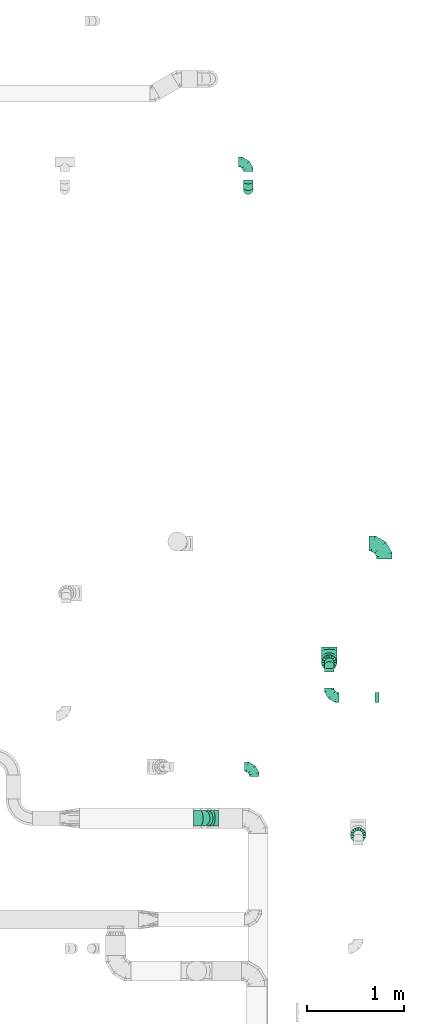
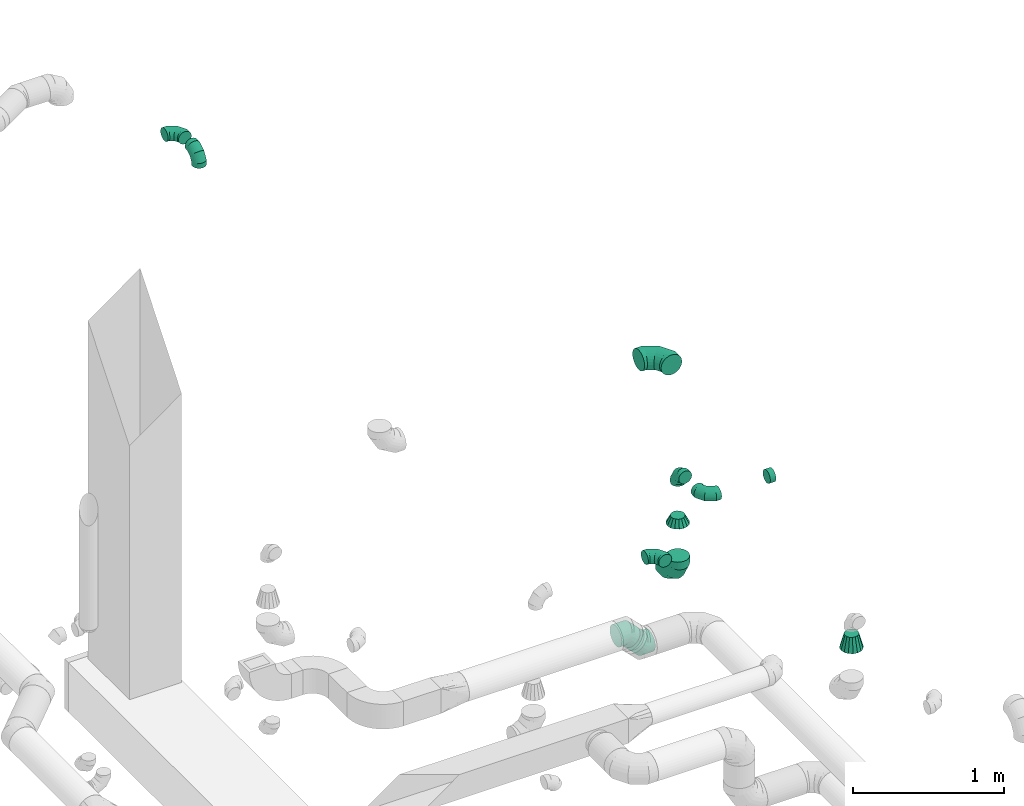
# One storey, part 83 of 97: 12 flow fittings.
"""IFC2X3 building model written with IfcOpenShell, lengths in millimetres."""

import ifcopenshell
import ifcopenshell.guid

model = None  # the IFC model being written
_history = None  # IfcOwnerHistory: only IFC2X3 demands one
_inside = {}  # id of a spatial element -> (the spatial element, [elements in it])
_under = {}  # id of a project, library or spatial element -> (it, [spatial elements below it])
_declared = {}  # id of a project -> (the project, [libraries it declares])
_typed = {}  # id of a type object -> (the type object, [elements of that type])
_made_of = {}  # id of a material, layer set ... -> (it, [elements and type objects made of it])


def new_model(schema):
    """Start an empty IFC model of exactly this schema.

    Asked for "IFC4X3", IfcOpenShell would pick the latest addendum, in which some entities
    have other attributes; the version numbers below select the first issue.
    IFC2X3 requires an IfcOwnerHistory on every rooted entity: one is made here for all.
    """
    global model, _history
    if schema == "IFC4X3":
        model = ifcopenshell.file(schema_version=(4, 3, 0, 0))
    else:
        model = ifcopenshell.file(schema=schema)
    _inside.clear()
    _under.clear()
    _declared.clear()
    _typed.clear()
    _made_of.clear()
    _history = None
    if model.schema == "IFC2X3":
        org = make("IfcOrganization", Name="unknown")
        user = make(
            "IfcPersonAndOrganization",
            ThePerson=make("IfcPerson", FamilyName="unknown"),
            TheOrganization=org,
        )
        app = make(
            "IfcApplication",
            ApplicationDeveloper=org,
            Version="unknown",
            ApplicationFullName="unknown",
            ApplicationIdentifier="unknown",
        )
        _history = make(
            "IfcOwnerHistory",
            OwningUser=user,
            OwningApplication=app,
            ChangeAction="ADDED",
            CreationDate=0,
        )
    return model


def make(cls, **values):
    """One entity of the class cls with the attributes given. An attribute that is None is left unset."""
    return model.create_entity(
        cls, **{name: value for name, value in values.items() if value is not None}
    )


def entity(cls, *values):
    """Any entity or typed value of the class cls, its attributes in the order of the schema. None: left unset."""
    e = model.create_entity(cls)
    for i, value in enumerate(values):
        if value is not None:
            e[i] = value
    return e


def rooted(cls, **values):
    """An entity with a GlobalId (a new one), such as an element, a storey or a relation."""
    return make(cls, GlobalId=ifcopenshell.guid.new(), OwnerHistory=_history, **values)


def si_unit(unit_type, name, prefix=None):
    """IfcSIUnit, for example si_unit("LENGTHUNIT", "METRE", prefix="MILLI")."""
    return make("IfcSIUnit", UnitType=unit_type, Prefix=prefix, Name=name)


def converted_unit(unit_type, name, factor, base, dimensions=None, offset=None):
    """IfcConversionBasedUnit, such as the inch: factor (a typed value) times the base unit."""
    return make(
        "IfcConversionBasedUnit"
        if offset is None
        else "IfcConversionBasedUnitWithOffset",
        ConversionOffset=offset,
        Dimensions=None
        if dimensions is None
        else entity("IfcDimensionalExponents", *dimensions),
        UnitType=unit_type,
        Name=name,
        ConversionFactor=make(
            "IfcMeasureWithUnit", ValueComponent=factor, UnitComponent=base
        ),
    )


def derived_unit(unit_type, elements):
    """IfcDerivedUnit: a product of units, each with its exponent."""
    return make(
        "IfcDerivedUnit",
        Elements=[
            make("IfcDerivedUnitElement", Unit=unit, Exponent=power)
            for unit, power in elements
        ],
        UnitType=unit_type,
    )


def assignment(units):
    """IfcUnitAssignment: the units of a project."""
    return None if units is None else make("IfcUnitAssignment", Units=units)


def point(xyz):
    """IfcCartesianPoint."""
    return None if xyz is None else make("IfcCartesianPoint", Coordinates=xyz)


def direction(xyz):
    """IfcDirection."""
    return None if xyz is None else make("IfcDirection", DirectionRatios=xyz)


def frame(location, z_axis=None, x_axis=None):
    """IfcAxis2Placement3D, a coordinate frame: its origin and axes. An axis left out is left unset."""
    return make(
        "IfcAxis2Placement3D",
        Location=point(location),
        Axis=direction(z_axis),
        RefDirection=direction(x_axis),
    )


def origin():
    """The frame at (0, 0, 0) with its axes left unset."""
    return frame((0.0, 0.0, 0.0))


def place(relative_to, where):
    """IfcLocalPlacement: puts the frame where relative to a parent placement (None: the world)."""
    return make(
        "IfcLocalPlacement", PlacementRelTo=relative_to, RelativePlacement=where
    )


def context(
    kind, dimensions, precision=None, world=None, true_north=None, identifier=None
):
    """IfcGeometricRepresentationContext, for example the 3D "Model" context."""
    return make(
        "IfcGeometricRepresentationContext",
        ContextIdentifier=identifier,
        ContextType=kind,
        CoordinateSpaceDimension=dimensions,
        Precision=precision,
        WorldCoordinateSystem=world,
        TrueNorth=true_north,
    )


def subcontext(parent, identifier, kind, view, scale=None):
    """IfcGeometricRepresentationSubContext, for example "Body" below "Model"."""
    return make(
        "IfcGeometricRepresentationSubContext",
        ContextIdentifier=identifier,
        ContextType=kind,
        ParentContext=parent,
        TargetScale=scale,
        TargetView=view,
    )


def project(units=None, contexts=None):
    """IfcProject with its units and contexts."""
    return rooted(
        "IfcProject",
        Name="project",
        RepresentationContexts=contexts,
        UnitsInContext=assignment(units),
    )


def spatial(cls, under=None, at=None, **own):
    """A site, building, storey or space (cls), placed at a placement, below another one or the project."""
    s = rooted(cls, ObjectPlacement=at, **own)
    if under is not None:
        _under.setdefault(under.id(), (under, []))[1].append(s)
    return s


def faces_of(points, faces, orient=None, outer=None):
    """IfcFace entities. A face is a list of loops; a loop is a list of indices into points, from 0.

    orient and outer hold one flag for each loop. By default every Orientation is true, the
    first loop of a face is its IfcFaceOuterBound and the others are IfcFaceBound.
    """
    made = []
    for i, loops in enumerate(faces):
        bounds = []
        for j, loop in enumerate(loops):
            is_outer = j == 0 if outer is None else outer[i][j]
            bounds.append(
                make(
                    "IfcFaceOuterBound" if is_outer else "IfcFaceBound",
                    Bound=make("IfcPolyLoop", Polygon=[points[k] for k in loop]),
                    Orientation=True if orient is None else orient[i][j],
                )
            )
        made.append(make("IfcFace", Bounds=bounds))
    return made


def faceted_brep(points, faces, orient=None, outer=None, voids=None):
    """IfcFacetedBrep: a solid bounded by flat faces; with voids (closed shells), ...WithVoids."""
    shared = [point(p) for p in points]
    hull = make("IfcClosedShell", CfsFaces=faces_of(shared, faces, orient, outer))
    if voids is None:
        return make("IfcFacetedBrep", Outer=hull)
    return make(
        "IfcFacetedBrepWithVoids",
        Outer=hull,
        Voids=[
            make(cls, CfsFaces=faces_of(shared, fs, o, b)) for cls, fs, o, b in voids
        ],
    )


def shape(context_of_items, identifier, shape_type, items):
    """IfcShapeRepresentation: the items that make up one representation, for example the "Body"."""
    return make(
        "IfcShapeRepresentation",
        ContextOfItems=context_of_items,
        RepresentationIdentifier=identifier,
        RepresentationType=shape_type,
        Items=items,
    )


def source(mapping_origin, context_of_items, identifier, shape_type, items):
    """IfcRepresentationMap: a shape defined once, which mapped items show again and again."""
    return make(
        "IfcRepresentationMap",
        MappingOrigin=mapping_origin,
        MappedRepresentation=shape(context_of_items, identifier, shape_type, items),
    )


def transform(
    local_origin,
    x_axis=None,
    y_axis=None,
    z_axis=None,
    scale=None,
    scale2=None,
    scale3=None,
    uniform=True,
):
    """IfcCartesianTransformationOperator3D, or its non-uniform kind. x_axis, y_axis, z_axis: its Axis1, 2, 3."""
    if uniform:
        return make(
            "IfcCartesianTransformationOperator3D",
            Axis1=direction(x_axis),
            Axis2=direction(y_axis),
            LocalOrigin=point(local_origin),
            Scale=scale,
            Axis3=direction(z_axis),
        )
    return make(
        "IfcCartesianTransformationOperator3DnonUniform",
        Axis1=direction(x_axis),
        Axis2=direction(y_axis),
        LocalOrigin=point(local_origin),
        Scale=scale,
        Axis3=direction(z_axis),
        Scale2=scale2,
        Scale3=scale3,
    )


def mapped(mapping_source, mapping_target):
    """IfcMappedItem: shows the shape of a source again, moved by a transform."""
    return make(
        "IfcMappedItem", MappingSource=mapping_source, MappingTarget=mapping_target
    )


def material(Name=None, Category=None):
    """IfcMaterial."""
    return make("IfcMaterial", Name=Name, Category=Category)


def made_of(thing, what):
    """Note that an element or type object is made of a material, layer set ...; save() writes the relation."""
    if what is not None:
        _made_of.setdefault(what.id(), (what, []))[1].append(thing)
    return thing


def type_object(cls, material=None, **own):
    """A type object (cls), such as IfcWallType, which elements share."""
    return made_of(rooted(cls, **own), material)


def type_shapes(of_type, sources):
    """Give a type object the sources (RepresentationMaps) that its elements show as mapped items."""
    of_type.RepresentationMaps = sources


def element(
    cls,
    number,
    at=None,
    inside=None,
    cuts=None,
    type_object=None,
    material=None,
    context=None,
    identifier="Body",
    shape_type=None,
    held_by="IfcProductDefinitionShape",
    body=None,
    shapes=None,
    **own,
):
    """One element of the class cls, such as IfcWall. Its Tag is "e" and its number.

    at: its placement. inside: the storey or other place that contains it. cuts: it is an
    opening in that element (IfcRelVoidsElement). A single representation is given by context,
    identifier, shape_type and body (its items); several are given by shapes. held_by: the class
    of the entity that holds the representations. save() writes the other relations.
    """
    e = rooted(cls, Tag="e%d" % number, ObjectPlacement=at, **own)
    if body is not None:
        shapes = [shape(context, identifier, shape_type, body)]
    if shapes is not None:
        e.Representation = make(held_by, Representations=shapes)
    if inside is not None:
        _inside.setdefault(inside.id(), (inside, []))[1].append(e)
    if cuts is not None:
        rooted(
            "IfcRelVoidsElement", RelatingBuildingElement=cuts, RelatedOpeningElement=e
        )
    if type_object is not None:
        _typed.setdefault(type_object.id(), (type_object, []))[1].append(e)
    return made_of(e, material)


def aggregate(whole, parts):
    """IfcRelAggregates: a whole, such as a stair, and the parts it consists of."""
    return rooted("IfcRelAggregates", RelatingObject=whole, RelatedObjects=parts)


def save(model, path):
    """Write the relations noted so far, then the file.

    IfcRelAggregates (storeys below a building ...), IfcRelContainedInSpatialStructure (elements
    in a storey), IfcRelDefinesByType, IfcRelAssociatesMaterial and IfcRelDeclares: one each for
    every whole, place, type object, material and project.
    """
    for whole, parts in _under.values():
        aggregate(whole, parts)
    for where, things in _inside.values():
        rooted(
            "IfcRelContainedInSpatialStructure",
            RelatedElements=things,
            RelatingStructure=where,
        )
    for kind, things in _typed.values():
        rooted("IfcRelDefinesByType", RelatedObjects=things, RelatingType=kind)
    for what, things in _made_of.values():
        rooted("IfcRelAssociatesMaterial", RelatedObjects=things, RelatingMaterial=what)
    for by, libraries in _declared.values():
        rooted("IfcRelDeclares", RelatingContext=by, RelatedDefinitions=libraries)
    model.write(path)


model = new_model("IFC2X3")

# Units and contexts
model_context = context("Model", 3, precision=0.01, world=origin(), true_north=direction((6.12303176911189e-17, 1.0)))
body_context = subcontext(model_context, "Body", "Model", "MODEL_VIEW")
ifc_project = project(units=[si_unit("LENGTHUNIT", "METRE", prefix="MILLI"), si_unit("AREAUNIT", "SQUARE_METRE"), si_unit("VOLUMEUNIT", "CUBIC_METRE"), converted_unit("PLANEANGLEUNIT", "DEGREE", entity("IfcRatioMeasure", 0.0174532925199433), si_unit("PLANEANGLEUNIT", "RADIAN"), dimensions=[0, 0, 0, 0, 0, 0, 0]), si_unit("MASSUNIT", "GRAM", prefix="KILO"), derived_unit("MASSDENSITYUNIT", [(si_unit("MASSUNIT", "GRAM", prefix="KILO"), 1), (si_unit("LENGTHUNIT", "METRE"), -3)]), derived_unit("MOMENTOFINERTIAUNIT", [(si_unit("LENGTHUNIT", "METRE"), 4)]), si_unit("TIMEUNIT", "SECOND"), si_unit("FREQUENCYUNIT", "HERTZ"), si_unit("THERMODYNAMICTEMPERATUREUNIT", "DEGREE_CELSIUS"), derived_unit("THERMALTRANSMITTANCEUNIT", [(si_unit("MASSUNIT", "GRAM", prefix="KILO"), 1), (si_unit("THERMODYNAMICTEMPERATUREUNIT", "KELVIN"), -1), (si_unit("TIMEUNIT", "SECOND"), -3)]), derived_unit("VOLUMETRICFLOWRATEUNIT", [(si_unit("LENGTHUNIT", "METRE"), 3), (si_unit("TIMEUNIT", "SECOND"), -1)]), derived_unit("MASSFLOWRATEUNIT", [(si_unit("MASSUNIT", "GRAM", prefix="KILO"), 1), (si_unit("TIMEUNIT", "SECOND"), -1)]), derived_unit("ROTATIONALFREQUENCYUNIT", [(si_unit("TIMEUNIT", "SECOND"), -1)]), si_unit("ELECTRICCURRENTUNIT", "AMPERE"), si_unit("ELECTRICVOLTAGEUNIT", "VOLT"), si_unit("POWERUNIT", "WATT"), si_unit("FORCEUNIT", "NEWTON", prefix="KILO"), si_unit("ILLUMINANCEUNIT", "LUX"), si_unit("LUMINOUSFLUXUNIT", "LUMEN"), si_unit("LUMINOUSINTENSITYUNIT", "CANDELA"), derived_unit("USERDEFINED", [(si_unit("MASSUNIT", "GRAM", prefix="KILO"), -1), (si_unit("LENGTHUNIT", "METRE"), -2), (si_unit("TIMEUNIT", "SECOND"), 3), (si_unit("LUMINOUSFLUXUNIT", "LUMEN"), 1)]), derived_unit("LINEARVELOCITYUNIT", [(si_unit("LENGTHUNIT", "METRE"), 1), (si_unit("TIMEUNIT", "SECOND"), -1)]), si_unit("PRESSUREUNIT", "PASCAL"), derived_unit("USERDEFINED", [(si_unit("LENGTHUNIT", "METRE"), -2), (si_unit("MASSUNIT", "GRAM", prefix="KILO"), 1), (si_unit("TIMEUNIT", "SECOND"), -2)]), derived_unit("LINEARFORCEUNIT", [(si_unit("MASSUNIT", "GRAM", prefix="KILO"), 1), (si_unit("LENGTHUNIT", "METRE"), 1), (si_unit("TIMEUNIT", "SECOND"), -2), (si_unit("LENGTHUNIT", "METRE"), -1)]), derived_unit("PLANARFORCEUNIT", [(si_unit("MASSUNIT", "GRAM", prefix="KILO"), 1), (si_unit("LENGTHUNIT", "METRE"), 1), (si_unit("TIMEUNIT", "SECOND"), -2), (si_unit("LENGTHUNIT", "METRE"), -2)])], contexts=[model_context])

# Site, building, storey
site_placement = place(None, origin())
site = spatial("IfcSite", under=ifc_project, at=site_placement, CompositionType="ELEMENT")
building_placement = place(site_placement, origin())
building = spatial("IfcBuilding", under=site, at=building_placement, CompositionType="ELEMENT")
storey_placement = place(building_placement, frame((0.0, 0.0, -4900.0)))
storey = spatial("IfcBuildingStorey", under=building, at=storey_placement, CompositionType="ELEMENT", Elevation=-4900.0)

# Flow fittings
ifc_material = material()
duct_fitting_type_1 = type_object("IfcDuctFittingType", PredefinedType="NOTDEFINED", material=ifc_material)
shared_shape_1 = source(origin(), body_context, "Body", "Brep", [
    faceted_brep([(-160.0, 0.0, -80.0), (-160.0, -20.71, -77.27), (-160.0, -40.0, -69.28), (-160.0, -56.57, -56.57), (-160.0, -69.28, -40.0), (-160.0, -77.27, -20.71), (-160.0, -80.0, 0.0), (-160.0, -77.27, 20.71), (-160.0, -69.28, 40.0), (-160.0, -56.57, 56.57), (-160.0, -40.0, 69.28), (-160.0, -20.71, 77.27), (-160.0, 0.0, 80.0), (-160.0, 20.71, 77.27), (-160.0, 40.0, 69.28), (-160.0, 56.57, 56.57), (-160.0, 69.28, 40.0), (-160.0, 77.27, 20.71), (-160.0, 80.0, 0.0), (-160.0, 77.27, -20.71), (-160.0, 69.28, -40.0), (-160.0, 56.57, -56.57), (-160.0, 40.0, -69.28), (-160.0, 20.71, -77.27), (-122.68, 20.71, 77.27), (-127.85, 40.0, 69.28), (-117.13, 0.0, 80.0), (-132.29, 56.57, 56.57), (-137.83, 77.27, 20.71), (-138.56, 80.0, 0.0), (-135.69, 69.28, 40.0), (-135.69, 69.28, -40.0), (-132.29, 56.57, -56.57), (-137.83, 77.27, -20.71), (-122.68, 20.71, -77.27), (-117.13, 0.0, -80.0), (-127.85, 40.0, -69.28), (-111.58, -20.71, -77.27), (-106.41, -40.0, -69.28), (-101.97, -56.57, -56.57), (-98.56, -69.28, -40.0), (-96.42, -77.27, -20.71), (-95.69, -80.0, 0.0), (-96.42, -77.27, 20.71), (-98.56, -69.28, 40.0), (-101.97, -56.57, 56.57), (-106.41, -40.0, 69.28), (-111.58, -20.71, 77.27), (-58.03, 58.03, 77.27), (-72.15, 72.15, 69.28), (-42.87, 42.87, 80.0), (-84.28, 84.28, 56.57), (-93.59, 93.59, 40.0), (-99.44, 99.44, 20.71), (-101.44, 101.44, 0.0), (-99.44, 99.44, -20.71), (-93.59, 93.59, -40.0), (-84.28, 84.28, -56.57), (-58.03, 58.03, -77.27), (-42.87, 42.87, -80.0), (-72.15, 72.15, -69.28), (-27.71, 27.71, -77.27), (-13.59, 13.59, -69.28), (-1.46, 1.46, -56.57), (7.85, -7.85, -40.0), (13.7, -13.7, -20.71), (15.69, -15.69, 0.0), (13.7, -13.7, 20.71), (7.85, -7.85, 40.0), (-1.46, 1.46, 56.57), (-13.59, 13.59, 69.28), (-27.71, 27.71, 77.27), (-20.71, 122.68, 77.27), (-40.0, 127.85, 69.28), (0.0, 117.13, 80.0), (-56.57, 132.29, 56.57), (-69.28, 135.69, 40.0), (-77.27, 137.83, 20.71), (-80.0, 138.56, 0.0), (-77.27, 137.83, -20.71), (-69.28, 135.69, -40.0), (-56.57, 132.29, -56.57), (-20.71, 122.68, -77.27), (0.0, 117.13, -80.0), (-40.0, 127.85, -69.28), (20.71, 111.58, -77.27), (40.0, 106.41, -69.28), (56.57, 101.97, -56.57), (69.28, 98.56, -40.0), (77.27, 96.42, -20.71), (80.0, 95.69, 0.0), (77.27, 96.42, 20.71), (69.28, 98.56, 40.0), (56.57, 101.97, 56.57), (40.0, 106.41, 69.28), (20.71, 111.58, 77.27), (-20.71, 160.0, -77.27), (-40.0, 160.0, -69.28), (-56.57, 160.0, -56.57), (-69.28, 160.0, -40.0), (-77.27, 160.0, -20.71), (-80.0, 160.0, 0.0), (-77.27, 160.0, 20.71), (-69.28, 160.0, 40.0), (-56.57, 160.0, 56.57), (-40.0, 160.0, 69.28), (-20.71, 160.0, 77.27), (0.0, 160.0, 80.0), (20.71, 160.0, 77.27), (40.0, 160.0, 69.28), (56.57, 160.0, 56.57), (69.28, 160.0, 40.0), (77.27, 160.0, 20.71), (80.0, 160.0, 0.0), (77.27, 160.0, -20.71), (69.28, 160.0, -40.0), (56.57, 160.0, -56.57), (40.0, 160.0, -69.28), (20.71, 160.0, -77.27), (0.0, 160.0, -80.0)], [[[0, 1, 2, 3, 4, 5, 6, 7, 8, 9, 10, 11, 12, 13, 14, 15, 16, 17, 18, 19, 20, 21, 22, 23]], [[24, 25, 14, 13]], [[26, 24, 13, 12]], [[14, 25, 27, 15]], [[28, 29, 18, 17]], [[30, 28, 17, 16]], [[15, 27, 30, 16]], [[20, 31, 32, 21]], [[33, 31, 20, 19]], [[18, 29, 33, 19]], [[34, 35, 0, 23]], [[36, 34, 23, 22]], [[32, 36, 22, 21]], [[1, 0, 35, 37]], [[2, 1, 37, 38]], [[3, 2, 38, 39]], [[5, 4, 40, 41]], [[6, 5, 41, 42]], [[39, 40, 4, 3]], [[6, 42, 43, 7]], [[7, 43, 44, 8]], [[8, 44, 45, 9]], [[9, 45, 46, 10]], [[10, 46, 47, 11]], [[26, 12, 11, 47]], [[48, 49, 25, 24]], [[50, 48, 24, 26]], [[27, 25, 49, 51]], [[52, 53, 28, 30]], [[51, 52, 30, 27]], [[29, 28, 53, 54]], [[55, 56, 31, 33]], [[54, 55, 33, 29]], [[32, 31, 56, 57]], [[58, 59, 35, 34]], [[60, 58, 34, 36]], [[57, 60, 36, 32]], [[37, 35, 59, 61]], [[38, 37, 61, 62]], [[39, 38, 62, 63]], [[41, 40, 64, 65]], [[42, 41, 65, 66]], [[63, 64, 40, 39]], [[43, 42, 66, 67]], [[44, 43, 67, 68]], [[68, 69, 45, 44]], [[46, 45, 69, 70]], [[47, 46, 70, 71]], [[26, 47, 71, 50]], [[72, 73, 49, 48]], [[74, 72, 48, 50]], [[51, 49, 73, 75]], [[76, 77, 53, 52]], [[75, 76, 52, 51]], [[54, 53, 77, 78]], [[79, 80, 56, 55]], [[78, 79, 55, 54]], [[57, 56, 80, 81]], [[82, 83, 59, 58]], [[84, 82, 58, 60]], [[81, 84, 60, 57]], [[61, 59, 83, 85]], [[62, 61, 85, 86]], [[63, 62, 86, 87]], [[65, 64, 88, 89]], [[66, 65, 89, 90]], [[87, 88, 64, 63]], [[67, 66, 90, 91]], [[68, 67, 91, 92]], [[92, 93, 69, 68]], [[70, 69, 93, 94]], [[71, 70, 94, 95]], [[50, 71, 95, 74]], [[96, 97, 98, 99, 100, 101, 102, 103, 104, 105, 106, 107, 108, 109, 110, 111, 112, 113, 114, 115, 116, 117, 118, 119]], [[72, 74, 107, 106]], [[73, 72, 106, 105]], [[75, 73, 105, 104]], [[77, 76, 103, 102]], [[78, 77, 102, 101]], [[75, 104, 103, 76]], [[78, 101, 100, 79]], [[79, 100, 99, 80]], [[80, 99, 98, 81]], [[84, 97, 96, 82]], [[82, 96, 119, 83]], [[84, 81, 98, 97]], [[118, 117, 86, 85]], [[119, 118, 85, 83]], [[116, 87, 86, 117]], [[88, 115, 114, 89]], [[89, 114, 113, 90]], [[115, 88, 87, 116]], [[112, 111, 92, 91]], [[113, 112, 91, 90]], [[111, 110, 93, 92]], [[95, 94, 109, 108]], [[74, 95, 108, 107]], [[110, 109, 94, 93]]]),
])
type_shapes(duct_fitting_type_1, [shared_shape_1])
for number, where, z_axis, x_axis in (
    (1, (72961.25, 14069.73, 4100.0), (0.0, 0.0, 1.0), (0.0, 1.0, 0.0)),
    (2, (72389.32, 12836.0, 3247.0), (-1.0, 0.0, 0.0), (0.0, -1.0, 0.0)),
):
    element("IfcFlowFitting", number, at=place(storey_placement, frame(where, z_axis=z_axis, x_axis=x_axis)), inside=storey, type_object=duct_fitting_type_1, material=ifc_material, context=body_context, shape_type="MappedRepresentation", body=[
        mapped(shared_shape_1, transform((0.0, 0.0, 0.0), scale=1.0)),
    ])
duct_fitting_type_2 = type_object("IfcDuctFittingType", PredefinedType="NOTDEFINED", material=ifc_material)
shared_shape_2 = source(origin(), body_context, "Body", "Brep", [
    faceted_brep([(-100.0, 0.0, -50.0), (-100.0, -12.94, -48.3), (-100.0, -25.0, -43.3), (-100.0, -35.36, -35.36), (-100.0, -43.3, -25.0), (-100.0, -48.3, -12.94), (-100.0, -50.0, 0.0), (-100.0, -48.3, 12.94), (-100.0, -43.3, 25.0), (-100.0, -35.36, 35.36), (-100.0, -25.0, 43.3), (-100.0, -12.94, 48.3), (-100.0, 0.0, 50.0), (-100.0, 12.94, 48.3), (-100.0, 25.0, 43.3), (-100.0, 35.36, 35.36), (-100.0, 43.3, 25.0), (-100.0, 48.3, 12.94), (-100.0, 50.0, 0.0), (-100.0, 48.3, -12.94), (-100.0, 43.3, -25.0), (-100.0, 35.36, -35.36), (-100.0, 25.0, -43.3), (-100.0, 12.94, -48.3), (-76.67, 12.94, 48.3), (-79.9, 25.0, 43.3), (-73.21, 0.0, 50.0), (-82.68, 35.36, 35.36), (-86.15, 48.3, 12.94), (-86.6, 50.0, 0.0), (-84.81, 43.3, 25.0), (-84.81, 43.3, -25.0), (-82.68, 35.36, -35.36), (-86.15, 48.3, -12.94), (-76.67, 12.94, -48.3), (-73.21, 0.0, -50.0), (-79.9, 25.0, -43.3), (-69.74, -12.94, -48.3), (-66.51, -25.0, -43.3), (-63.73, -35.36, -35.36), (-61.6, -43.3, -25.0), (-60.26, -48.3, -12.94), (-59.81, -50.0, 0.0), (-60.26, -48.3, 12.94), (-61.6, -43.3, 25.0), (-63.73, -35.36, 35.36), (-66.51, -25.0, 43.3), (-69.74, -12.94, 48.3), (-36.27, 36.27, 48.3), (-45.1, 45.1, 43.3), (-26.79, 26.79, 50.0), (-52.68, 52.68, 35.36), (-58.49, 58.49, 25.0), (-62.15, 62.15, 12.94), (-63.4, 63.4, 0.0), (-62.15, 62.15, -12.94), (-58.49, 58.49, -25.0), (-52.68, 52.68, -35.36), (-36.27, 36.27, -48.3), (-26.79, 26.79, -50.0), (-45.1, 45.1, -43.3), (-17.32, 17.32, -48.3), (-8.49, 8.49, -43.3), (-0.91, 0.91, -35.36), (4.9, -4.9, -25.0), (8.56, -8.56, -12.94), (9.81, -9.81, 0.0), (8.56, -8.56, 12.94), (4.9, -4.9, 25.0), (-0.91, 0.91, 35.36), (-8.49, 8.49, 43.3), (-17.32, 17.32, 48.3), (-12.94, 76.67, 48.3), (-25.0, 79.9, 43.3), (0.0, 73.21, 50.0), (-35.36, 82.68, 35.36), (-43.3, 84.81, 25.0), (-48.3, 86.15, 12.94), (-50.0, 86.6, 0.0), (-48.3, 86.15, -12.94), (-43.3, 84.81, -25.0), (-35.36, 82.68, -35.36), (-12.94, 76.67, -48.3), (0.0, 73.21, -50.0), (-25.0, 79.9, -43.3), (12.94, 69.74, -48.3), (25.0, 66.51, -43.3), (35.36, 63.73, -35.36), (43.3, 61.6, -25.0), (48.3, 60.26, -12.94), (50.0, 59.81, 0.0), (48.3, 60.26, 12.94), (43.3, 61.6, 25.0), (35.36, 63.73, 35.36), (25.0, 66.51, 43.3), (12.94, 69.74, 48.3), (-12.94, 100.0, -48.3), (-25.0, 100.0, -43.3), (-35.36, 100.0, -35.36), (-43.3, 100.0, -25.0), (-48.3, 100.0, -12.94), (-50.0, 100.0, 0.0), (-48.3, 100.0, 12.94), (-43.3, 100.0, 25.0), (-35.36, 100.0, 35.36), (-25.0, 100.0, 43.3), (-12.94, 100.0, 48.3), (0.0, 100.0, 50.0), (12.94, 100.0, 48.3), (25.0, 100.0, 43.3), (35.36, 100.0, 35.36), (43.3, 100.0, 25.0), (48.3, 100.0, 12.94), (50.0, 100.0, 0.0), (48.3, 100.0, -12.94), (43.3, 100.0, -25.0), (35.36, 100.0, -35.36), (25.0, 100.0, -43.3), (12.94, 100.0, -48.3), (0.0, 100.0, -50.0)], [[[0, 1, 2, 3, 4, 5, 6, 7, 8, 9, 10, 11, 12, 13, 14, 15, 16, 17, 18, 19, 20, 21, 22, 23]], [[24, 25, 14, 13]], [[26, 24, 13, 12]], [[14, 25, 27, 15]], [[28, 29, 18, 17]], [[30, 28, 17, 16]], [[15, 27, 30, 16]], [[20, 31, 32, 21]], [[33, 31, 20, 19]], [[18, 29, 33, 19]], [[34, 35, 0, 23]], [[36, 34, 23, 22]], [[32, 36, 22, 21]], [[2, 1, 37, 38]], [[3, 2, 38, 39]], [[0, 35, 37, 1]], [[5, 4, 40, 41]], [[6, 5, 41, 42]], [[3, 39, 40, 4]], [[6, 42, 43, 7]], [[7, 43, 44, 8]], [[8, 44, 45, 9]], [[10, 46, 47, 11]], [[11, 47, 26, 12]], [[10, 9, 45, 46]], [[48, 49, 25, 24]], [[50, 48, 24, 26]], [[27, 25, 49, 51]], [[52, 53, 28, 30]], [[51, 52, 30, 27]], [[29, 28, 53, 54]], [[55, 56, 31, 33]], [[54, 55, 33, 29]], [[57, 32, 31, 56]], [[58, 59, 35, 34]], [[60, 58, 34, 36]], [[57, 60, 36, 32]], [[37, 35, 59, 61]], [[38, 37, 61, 62]], [[39, 38, 62, 63]], [[41, 40, 64, 65]], [[42, 41, 65, 66]], [[63, 64, 40, 39]], [[43, 42, 66, 67]], [[44, 43, 67, 68]], [[68, 69, 45, 44]], [[46, 45, 69, 70]], [[47, 46, 70, 71]], [[26, 47, 71, 50]], [[72, 73, 49, 48]], [[74, 72, 48, 50]], [[51, 49, 73, 75]], [[76, 77, 53, 52]], [[75, 76, 52, 51]], [[54, 53, 77, 78]], [[79, 80, 56, 55]], [[78, 79, 55, 54]], [[81, 57, 56, 80]], [[82, 83, 59, 58]], [[84, 82, 58, 60]], [[81, 84, 60, 57]], [[61, 59, 83, 85]], [[62, 61, 85, 86]], [[63, 62, 86, 87]], [[65, 64, 88, 89]], [[66, 65, 89, 90]], [[87, 88, 64, 63]], [[67, 66, 90, 91]], [[68, 67, 91, 92]], [[92, 93, 69, 68]], [[70, 69, 93, 94]], [[71, 70, 94, 95]], [[50, 71, 95, 74]], [[96, 97, 98, 99, 100, 101, 102, 103, 104, 105, 106, 107, 108, 109, 110, 111, 112, 113, 114, 115, 116, 117, 118, 119]], [[72, 74, 107, 106]], [[73, 72, 106, 105]], [[75, 73, 105, 104]], [[77, 76, 103, 102]], [[78, 77, 102, 101]], [[75, 104, 103, 76]], [[78, 101, 100, 79]], [[79, 100, 99, 80]], [[80, 99, 98, 81]], [[96, 119, 83, 82]], [[97, 96, 82, 84]], [[84, 81, 98, 97]], [[83, 119, 118, 85]], [[85, 118, 117, 86]], [[86, 117, 116, 87]], [[88, 115, 114, 89]], [[89, 114, 113, 90]], [[87, 116, 115, 88]], [[91, 90, 113, 112]], [[92, 91, 112, 111]], [[93, 92, 111, 110]], [[95, 94, 109, 108]], [[74, 95, 108, 107]], [[110, 109, 94, 93]]]),
])
type_shapes(duct_fitting_type_2, [shared_shape_2])
for number, where, z_axis, x_axis in (
    (3, (72389.32, 12474.53, 4100.0), (0.0, 0.0, 1.0), (0.0, -1.0, 0.0)),
    (4, (72389.32, 12836.0, 4100.0), (-1.0, 0.0, 0.0), (0.0, 1.0, 0.0)),
    (5, (71612.63, 11756.75, 4350.0), (0.0, 0.0, 1.0), (0.0, 1.0, 0.0)),
    (6, (71548.96, 18023.14, 4000.0), (0.0, 0.0, 1.0), (0.0, 1.0, 0.0)),
    (7, (71548.96, 17736.71, 4000.0), (1.0, 0.0, 0.0), (0.0, -1.0, 0.0)),
):
    element("IfcFlowFitting", number, at=place(storey_placement, frame(where, z_axis=z_axis, x_axis=x_axis)), inside=storey, type_object=duct_fitting_type_2, material=ifc_material, context=body_context, shape_type="MappedRepresentation", body=[
        mapped(shared_shape_2, transform((0.0, 0.0, 0.0), scale=1.0)),
    ])
duct_fitting_type_3 = type_object("IfcDuctFittingType", PredefinedType="NOTDEFINED", material=ifc_material)
shared_shape_3 = source(origin(), body_context, "Body", "Brep", [
    faceted_brep([(20.0, 12.94, -48.3), (20.0, 25.0, -43.3), (20.0, 35.36, -35.36), (20.0, 43.3, -25.0), (20.0, 48.3, -12.94), (20.0, 50.0, 0.0), (20.0, 48.3, 12.94), (20.0, 43.3, 25.0), (20.0, 35.36, 35.36), (20.0, 25.0, 43.3), (20.0, 12.94, 48.3), (20.0, 0.0, 50.0), (20.0, -12.94, 48.3), (20.0, -25.0, 43.3), (20.0, -35.36, 35.36), (20.0, -43.3, 25.0), (20.0, -48.3, 12.94), (20.0, -50.0, 0.0), (20.0, -48.3, -12.94), (20.0, -43.3, -25.0), (20.0, -35.36, -35.36), (20.0, -25.0, -43.3), (20.0, -12.94, -48.3), (20.0, 0.0, -50.0), (0.0, 0.0, 50.0), (0.0, 12.94, 48.3), (-23.65, 12.94, 48.3), (-23.65, 0.0, 50.0), (0.0, 25.0, 43.3), (-23.65, 25.0, 43.3), (0.0, 35.36, 35.36), (-23.65, 35.36, 35.36), (0.0, 43.3, 25.0), (0.0, 48.3, 12.94), (-23.65, 48.3, 12.94), (-23.65, 43.3, 25.0), (0.0, 50.0, 0.0), (-23.65, 50.0, 0.0), (0.0, 48.3, -12.94), (-23.65, 48.3, -12.94), (0.0, 43.3, -25.0), (-23.65, 43.3, -25.0), (0.0, 35.36, -35.36), (-23.65, 35.36, -35.36), (0.0, 25.0, -43.3), (0.0, 12.94, -48.3), (-23.65, 12.94, -48.3), (-23.65, 25.0, -43.3), (0.0, 0.0, -50.0), (-23.65, 0.0, -50.0), (0.0, -12.94, -48.3), (-23.65, -12.94, -48.3), (0.0, -25.0, -43.3), (-23.65, -25.0, -43.3), (0.0, -35.36, -35.36), (-23.65, -35.36, -35.36), (0.0, -43.3, -25.0), (0.0, -48.3, -12.94), (-23.65, -48.3, -12.94), (-23.65, -43.3, -25.0), (0.0, -50.0, 0.0), (-23.65, -50.0, 0.0), (0.0, -48.3, 12.94), (-23.65, -48.3, 12.94), (0.0, -43.3, 25.0), (-23.65, -43.3, 25.0), (0.0, -35.36, 35.36), (-23.65, -35.36, 35.36), (0.0, -25.0, 43.3), (0.0, -12.94, 48.3), (-23.65, -12.94, 48.3), (-23.65, -25.0, 43.3)], [[[0, 1, 2, 3, 4, 5, 6, 7, 8, 9, 10, 11, 12, 13, 14, 15, 16, 17, 18, 19, 20, 21, 22, 23]], [[24, 11, 10, 25, 26, 27]], [[25, 10, 9, 28, 29, 26]], [[28, 9, 8, 30, 31, 29]], [[32, 7, 6, 33, 34, 35]], [[33, 6, 5, 36, 37, 34]], [[30, 8, 7, 32, 35, 31]], [[36, 5, 4, 38, 39, 37]], [[38, 4, 3, 40, 41, 39]], [[40, 3, 2, 42, 43, 41]], [[44, 1, 0, 45, 46, 47]], [[45, 0, 23, 48, 49, 46]], [[42, 2, 1, 44, 47, 43]], [[48, 23, 22, 50, 51, 49]], [[50, 22, 21, 52, 53, 51]], [[52, 21, 20, 54, 55, 53]], [[56, 19, 18, 57, 58, 59]], [[57, 18, 17, 60, 61, 58]], [[54, 20, 19, 56, 59, 55]], [[60, 17, 16, 62, 63, 61]], [[62, 16, 15, 64, 65, 63]], [[64, 15, 14, 66, 67, 65]], [[68, 13, 12, 69, 70, 71]], [[69, 12, 11, 24, 27, 70]], [[66, 14, 13, 68, 71, 67]], [[49, 51, 53, 55, 59, 58, 61, 63, 65, 67, 71, 70, 27, 26, 29, 31, 35, 34, 37, 39, 41, 43, 47, 46]]]),
])
type_shapes(duct_fitting_type_3, [shared_shape_3])
flow_fitting_1_placement = place(storey_placement, frame((72881.25, 12474.53, 4100.0), z_axis=(0.0, 0.0, -1.0), x_axis=(-1.0, 0.0, 0.0)))
element("IfcFlowFitting", 8, at=flow_fitting_1_placement, inside=storey, type_object=duct_fitting_type_3, material=ifc_material, context=body_context, shape_type="MappedRepresentation", body=[
    mapped(shared_shape_3, transform((0.0, 0.0, 0.0), scale=1.0)),
])
duct_fitting_type_4 = type_object("IfcDuctFittingType", PredefinedType="NOTDEFINED", material=ifc_material)
shared_shape_4 = source(origin(), body_context, "Body", "Brep", [
    faceted_brep([(60.0, -46.19, 19.13), (60.0, -48.1, 9.57), (60.0, -50.0, 0.0), (60.0, -48.1, -9.57), (60.0, -46.19, -19.13), (60.0, -40.77, -27.24), (60.0, -35.36, -35.36), (60.0, -27.24, -40.77), (60.0, -19.13, -46.19), (60.0, -9.57, -48.1), (60.0, 0.0, -50.0), (60.0, 9.57, -48.1), (60.0, 19.13, -46.19), (60.0, 27.24, -40.77), (60.0, 35.36, -35.36), (60.0, 40.77, -27.24), (60.0, 46.19, -19.13), (60.0, 48.1, -9.57), (60.0, 50.0, 0.0), (60.0, 48.1, 9.57), (60.0, 46.19, 19.13), (60.0, 40.77, 27.24), (60.0, 35.36, 35.36), (60.0, 27.24, 40.77), (60.0, 19.13, 46.19), (60.0, 9.57, 48.1), (60.0, 0.0, 50.0), (60.0, -9.57, 48.1), (60.0, -19.13, 46.19), (60.0, -27.24, 40.77), (60.0, -35.36, 35.36), (60.0, -40.77, 27.24), (0.0, -80.0, 0.0), (0.0, -77.16, 14.27), (0.0, -73.91, 30.61), (0.0, -65.24, 43.59), (0.0, -56.57, 56.57), (0.0, -43.59, 65.24), (0.0, -30.61, 73.91), (0.0, -15.31, 76.96), (0.0, 0.0, 80.0), (0.0, 14.27, 77.16), (0.0, 30.61, 73.91), (0.0, 43.59, 65.24), (0.0, 56.57, 56.57), (0.0, 65.24, 43.59), (0.0, 73.91, 30.61), (0.0, 76.96, 15.31), (0.0, 80.0, 0.0), (0.0, 77.16, -14.27), (0.0, 73.91, -30.61), (0.0, 65.24, -43.59), (0.0, 56.57, -56.57), (0.0, 43.59, -65.24), (0.0, 30.61, -73.91), (0.0, 15.31, -76.96), (0.0, 0.0, -80.0), (0.0, -14.27, -77.16), (0.0, -30.61, -73.91), (0.0, -43.59, -65.24), (0.0, -56.57, -56.57), (0.0, -65.24, -43.59), (0.0, -73.91, -30.61), (0.0, -76.96, -15.31)], [[[0, 1, 2, 3, 4, 5, 6, 7, 8, 9, 10, 11, 12, 13, 14, 15, 16, 17, 18, 19, 20, 21, 22, 23, 24, 25, 26, 27, 28, 29, 30, 31]], [[32, 33, 34, 35, 36, 37, 38, 39, 40, 41, 42, 43, 44, 45, 46, 47, 48, 49, 50, 51, 52, 53, 54, 55, 56, 57, 58, 59, 60, 61, 62, 63]], [[42, 41, 40, 26, 25, 24]], [[43, 42, 24, 23, 22, 44]], [[20, 46, 45, 44, 22, 21]], [[18, 48, 47, 46, 20, 19]], [[34, 33, 32, 2, 1, 0]], [[35, 34, 0, 31, 30, 36]], [[28, 38, 37, 36, 30, 29]], [[26, 40, 39, 38, 28, 27]], [[58, 57, 56, 10, 9, 8]], [[59, 58, 8, 7, 6, 60]], [[4, 62, 61, 60, 6, 5]], [[2, 32, 63, 62, 4, 3]], [[50, 49, 48, 18, 17, 16]], [[51, 50, 16, 15, 14, 52]], [[12, 54, 53, 52, 14, 13]], [[10, 56, 55, 54, 12, 11]]]),
])
type_shapes(duct_fitting_type_4, [shared_shape_4])
flow_fitting_2_placement = place(storey_placement, frame((72389.32, 12836.0, 3674.0), z_axis=(0.0, -1.0, 0.0), x_axis=(0.0, 0.0, 1.0)))
element("IfcFlowFitting", 9, at=flow_fitting_2_placement, inside=storey, type_object=duct_fitting_type_4, material=ifc_material, context=body_context, shape_type="MappedRepresentation", body=[
    mapped(shared_shape_4, transform((0.0, 0.0, 0.0), scale=1.0)),
])
duct_fitting_type_5 = type_object("IfcDuctFittingType", PredefinedType="NOTDEFINED", material=ifc_material)
shared_shape_5 = source(origin(), body_context, "Body", "Brep", [
    faceted_brep([(-66.27, 0.0, -80.0), (-66.27, -20.71, -77.27), (-66.27, -40.0, -69.28), (-66.27, -56.57, -56.57), (-66.27, -69.28, -40.0), (-66.27, -77.27, -20.71), (-66.27, -80.0, 0.0), (-66.27, -77.27, 20.71), (-66.27, -69.28, 40.0), (-66.27, -56.57, 56.57), (-66.27, -40.0, 69.28), (-66.27, -20.71, 77.27), (-66.27, 0.0, 80.0), (-66.27, 20.71, 77.27), (-66.27, 40.0, 69.28), (-66.27, 56.57, 56.57), (-66.27, 69.28, 40.0), (-66.27, 77.27, 20.71), (-66.27, 80.0, 0.0), (-66.27, 77.27, -20.71), (-66.27, 69.28, -40.0), (-66.27, 56.57, -56.57), (-66.27, 40.0, -69.28), (-66.27, 20.71, -77.27), (-8.58, 20.71, 77.27), (-16.57, 40.0, 69.28), (0.0, 0.0, 80.0), (-23.43, 56.57, 56.57), (-28.7, 69.28, 40.0), (-32.01, 77.27, 20.71), (-33.14, 80.0, 0.0), (-32.01, 77.27, -20.71), (-28.7, 69.28, -40.0), (-23.43, 56.57, -56.57), (-8.58, 20.71, -77.27), (0.0, 0.0, -80.0), (-16.57, 40.0, -69.28), (8.58, -20.71, -77.27), (16.57, -40.0, -69.28), (23.43, -56.57, -56.57), (28.7, -69.28, -40.0), (32.01, -77.27, -20.71), (33.14, -80.0, 0.0), (32.01, -77.27, 20.71), (28.7, -69.28, 40.0), (23.43, -56.57, 56.57), (16.57, -40.0, 69.28), (8.58, -20.71, 77.27), (46.86, 46.86, 80.0), (32.22, 61.5, 77.27), (18.58, 75.15, 69.28), (6.86, 86.86, 56.57), (-2.13, 95.85, 40.0), (-7.78, 101.5, 20.71), (-9.71, 103.43, 0.0), (-7.78, 101.5, -20.71), (-2.13, 95.85, -40.0), (6.86, 86.86, -56.57), (18.58, 75.15, -69.28), (32.22, 61.5, -77.27), (46.86, 46.86, -80.0), (61.5, 32.22, -77.27), (75.15, 18.58, -69.28), (86.86, 6.86, -56.57), (95.85, -2.13, -40.0), (101.5, -7.78, -20.71), (103.43, -9.71, 0.0), (101.5, -7.78, 20.71), (95.85, -2.13, 40.0), (86.86, 6.86, 56.57), (75.15, 18.58, 69.28), (61.5, 32.22, 77.27)], [[[0, 1, 2, 3, 4, 5, 6, 7, 8, 9, 10, 11, 12, 13, 14, 15, 16, 17, 18, 19, 20, 21, 22, 23]], [[24, 25, 14, 13]], [[26, 24, 13, 12]], [[14, 25, 27, 15]], [[28, 29, 17, 16]], [[28, 16, 15, 27]], [[30, 18, 17, 29]], [[31, 32, 20, 19]], [[30, 31, 19, 18]], [[32, 33, 21, 20]], [[34, 35, 0, 23]], [[36, 34, 23, 22]], [[33, 36, 22, 21]], [[1, 0, 35, 37]], [[2, 1, 37, 38]], [[38, 39, 3, 2]], [[5, 4, 40, 41]], [[6, 5, 41, 42]], [[39, 40, 4, 3]], [[6, 42, 43, 7]], [[7, 43, 44, 8]], [[8, 44, 45, 9]], [[9, 45, 46, 10]], [[10, 46, 47, 11]], [[26, 12, 11, 47]], [[24, 26, 48, 49]], [[25, 24, 49, 50]], [[27, 25, 50, 51]], [[29, 28, 52, 53]], [[30, 29, 53, 54]], [[51, 52, 28, 27]], [[30, 54, 55, 31]], [[31, 55, 56, 32]], [[57, 33, 32, 56]], [[36, 58, 59, 34]], [[34, 59, 60, 35]], [[58, 36, 33, 57]], [[35, 60, 61, 37]], [[37, 61, 62, 38]], [[63, 39, 38, 62]], [[40, 64, 65, 41]], [[41, 65, 66, 42]], [[64, 40, 39, 63]], [[43, 42, 66, 67]], [[44, 43, 67, 68]], [[68, 69, 45, 44]], [[47, 46, 70, 71]], [[26, 47, 71, 48]], [[69, 70, 46, 45]], [[59, 58, 57, 56, 55, 54, 53, 52, 51, 50, 49, 48, 71, 70, 69, 68, 67, 66, 65, 64, 63, 62, 61, 60]]]),
])
type_shapes(duct_fitting_type_5, [shared_shape_5])
for number, where, z_axis, x_axis in (
    (10, (71049.67, 11223.58, 4225.0), (0.0, 1.0, 0.0), (1.0, 0.0, 0.0)),
    (11, (71174.67, 11223.58, 4100.0), (0.0, -1.0, 0.0), (0.707106781186529, 0.0, -0.707106781186566)),
):
    element("IfcFlowFitting", number, at=place(storey_placement, frame(where, z_axis=z_axis, x_axis=x_axis)), inside=storey, type_object=duct_fitting_type_5, material=ifc_material, context=body_context, shape_type="MappedRepresentation", body=[
        mapped(shared_shape_5, transform((0.0, 0.0, 0.0), scale=1.0)),
    ])
duct_fitting_type_6 = type_object("IfcDuctFittingType", PredefinedType="NOTDEFINED", material=ifc_material)
shared_shape_6 = source(origin(), body_context, "Body", "Brep", [
    faceted_brep([(112.0, -16.52, -76.71), (112.0, 0.0, -80.0), (112.0, 16.52, -76.71), (112.0, 30.61, -73.91), (112.0, 43.59, -65.24), (112.0, 56.57, -56.57), (112.0, 65.24, -43.59), (112.0, 73.91, -30.61), (112.0, 76.71, -16.52), (112.0, 80.0, 0.0), (112.0, 76.71, 16.52), (112.0, 73.91, 30.61), (112.0, 65.24, 43.59), (112.0, 56.57, 56.57), (112.0, 43.59, 65.24), (112.0, 30.61, 73.91), (112.0, 16.52, 76.71), (112.0, 0.0, 80.0), (112.0, -16.52, 76.71), (112.0, -30.61, 73.91), (112.0, -43.59, 65.24), (112.0, -56.57, 56.57), (112.0, -65.24, 43.59), (112.0, -73.91, 30.61), (112.0, -76.71, 16.52), (112.0, -80.0, 0.0), (112.0, -76.71, -16.52), (112.0, -73.91, -30.61), (112.0, -65.24, -43.59), (112.0, -56.57, -56.57), (112.0, -43.59, -65.24), (112.0, -30.61, -73.91), (0.0, 0.0, 50.0), (0.0, 9.57, 48.1), (0.0, 19.13, 46.19), (0.0, 27.24, 40.77), (0.0, 35.36, 35.36), (0.0, 40.77, 27.24), (0.0, 46.19, 19.13), (0.0, 48.1, 9.57), (0.0, 50.0, 0.0), (0.0, 48.1, -9.57), (0.0, 46.19, -19.13), (0.0, 40.77, -27.24), (0.0, 35.36, -35.36), (0.0, 27.24, -40.77), (0.0, 19.13, -46.19), (0.0, 9.57, -48.1), (0.0, 0.0, -50.0), (0.0, -9.57, -48.1), (0.0, -19.13, -46.19), (0.0, -27.24, -40.77), (0.0, -35.36, -35.36), (0.0, -40.77, -27.24), (0.0, -46.19, -19.13), (0.0, -48.1, -9.57), (0.0, -50.0, 0.0), (0.0, -48.1, 9.57), (0.0, -46.19, 19.13), (0.0, -40.77, 27.24), (0.0, -35.36, 35.36), (0.0, -27.24, 40.77), (0.0, -19.13, 46.19), (0.0, -9.57, 48.1)], [[[0, 1, 2, 3, 4, 5, 6, 7, 8, 9, 10, 11, 12, 13, 14, 15, 16, 17, 18, 19, 20, 21, 22, 23, 24, 25, 26, 27, 28, 29, 30, 31]], [[32, 33, 34, 35, 36, 37, 38, 39, 40, 41, 42, 43, 44, 45, 46, 47, 48, 49, 50, 51, 52, 53, 54, 55, 56, 57, 58, 59, 60, 61, 62, 63]], [[38, 11, 10, 9, 40, 39]], [[36, 13, 12, 11, 38, 37]], [[33, 32, 17, 16, 15, 34]], [[13, 36, 35, 34, 15, 14]], [[62, 19, 18, 17, 32, 63]], [[60, 21, 20, 19, 62, 61]], [[57, 56, 25, 24, 23, 58]], [[21, 60, 59, 58, 23, 22]], [[54, 27, 26, 25, 56, 55]], [[52, 29, 28, 27, 54, 53]], [[49, 48, 1, 0, 31, 50]], [[29, 52, 51, 50, 31, 30]], [[46, 3, 2, 1, 48, 47]], [[44, 5, 4, 3, 46, 45]], [[41, 40, 9, 8, 7, 42]], [[5, 44, 43, 42, 7, 6]]]),
])
type_shapes(duct_fitting_type_6, [shared_shape_6])
flow_fitting_3_placement = place(storey_placement, frame((72688.52, 11048.25, 3756.01), z_axis=(0.0, -1.0, 0.0), x_axis=(0.0, 0.0, -1.0)))
element("IfcFlowFitting", 12, at=flow_fitting_3_placement, inside=storey, type_object=duct_fitting_type_6, material=ifc_material, context=body_context, shape_type="MappedRepresentation", body=[
    mapped(shared_shape_6, transform((0.0, 0.0, 0.0), scale=1.0)),
])

save(model, "model.ifc")
